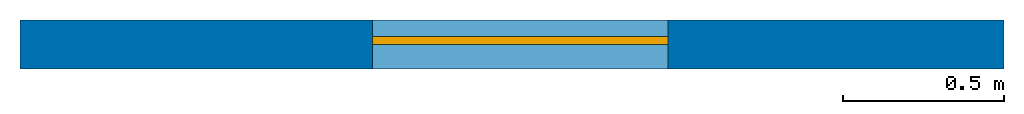
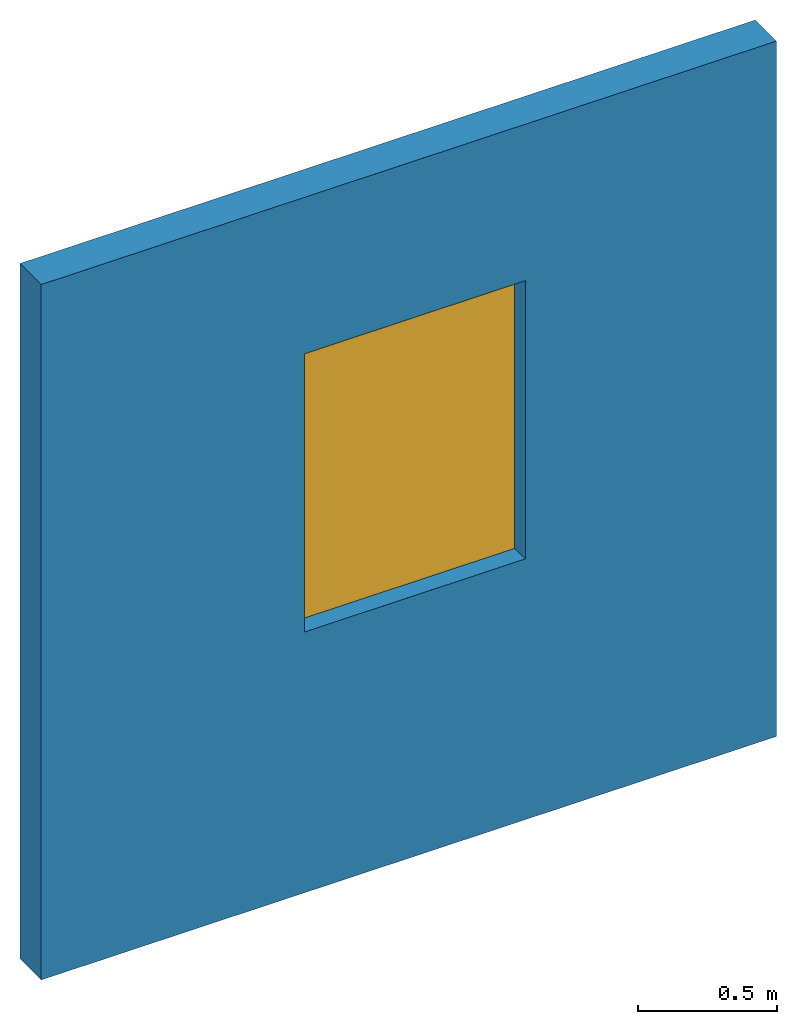
# One storey: 1 wall, 1 window, 1 opening.
"""IFC4 building model written with IfcOpenShell, lengths in feet."""

from ifc_helpers import new_model, entity, si_unit, converted_unit, derived_unit, direction, frame, frame_2d, origin, origin_2d_with_axis, place, context, subcontext, project, spatial, rectangle, extrude, source, transform, mapped, material, layer, layer_set, layer_usage, type_object, type_shapes, element, fill, save


model = new_model("IFC4")

# Units and contexts
model_context = context("Model", 3, precision=0.0001, world=origin(), true_north=direction((6.12303176911189e-17, 1.0)))
body_context = subcontext(model_context, "Body", "Model", "MODEL_VIEW")
ifc_project = project(units=[converted_unit("LENGTHUNIT", "FOOT", entity("IfcRatioMeasure", 0.3048), si_unit("LENGTHUNIT", "METRE"), dimensions=[1, 0, 0, 0, 0, 0, 0]), converted_unit("AREAUNIT", "SQUARE FOOT", entity("IfcRatioMeasure", 0.09290304), si_unit("AREAUNIT", "SQUARE_METRE"), dimensions=[2, 0, 0, 0, 0, 0, 0]), converted_unit("VOLUMEUNIT", "CUBIC FOOT", entity("IfcRatioMeasure", 0.028316846592), si_unit("VOLUMEUNIT", "CUBIC_METRE"), dimensions=[3, 0, 0, 0, 0, 0, 0]), converted_unit("PLANEANGLEUNIT", "DEGREE", entity("IfcRatioMeasure", 0.0174532925199433), si_unit("PLANEANGLEUNIT", "RADIAN"), dimensions=[0, 0, 0, 0, 0, 0, 0]), si_unit("MASSUNIT", "GRAM", prefix="KILO"), derived_unit("MASSDENSITYUNIT", [(si_unit("MASSUNIT", "GRAM", prefix="KILO"), 1), (si_unit("LENGTHUNIT", "METRE"), -3)]), derived_unit("MOMENTOFINERTIAUNIT", [(si_unit("LENGTHUNIT", "METRE"), 4)]), si_unit("TIMEUNIT", "SECOND"), si_unit("FREQUENCYUNIT", "HERTZ"), si_unit("THERMODYNAMICTEMPERATUREUNIT", "DEGREE_CELSIUS"), derived_unit("THERMALTRANSMITTANCEUNIT", [(si_unit("MASSUNIT", "GRAM", prefix="KILO"), 1), (si_unit("THERMODYNAMICTEMPERATUREUNIT", "KELVIN"), -1), (si_unit("TIMEUNIT", "SECOND"), -3)]), derived_unit("VOLUMETRICFLOWRATEUNIT", [(si_unit("LENGTHUNIT", "METRE"), 3), (si_unit("TIMEUNIT", "SECOND"), -1)]), si_unit("ELECTRICCURRENTUNIT", "AMPERE"), si_unit("ELECTRICVOLTAGEUNIT", "VOLT"), si_unit("POWERUNIT", "WATT"), si_unit("FORCEUNIT", "NEWTON"), si_unit("ILLUMINANCEUNIT", "LUX"), si_unit("LUMINOUSFLUXUNIT", "LUMEN"), si_unit("LUMINOUSINTENSITYUNIT", "CANDELA"), derived_unit("USERDEFINED", [(si_unit("MASSUNIT", "GRAM", prefix="KILO"), -1), (si_unit("LENGTHUNIT", "METRE"), -2), (si_unit("TIMEUNIT", "SECOND"), 3), (si_unit("LUMINOUSFLUXUNIT", "LUMEN"), 1)]), derived_unit("LINEARVELOCITYUNIT", [(si_unit("LENGTHUNIT", "METRE"), 1), (si_unit("TIMEUNIT", "SECOND"), -1)]), si_unit("PRESSUREUNIT", "PASCAL"), derived_unit("USERDEFINED", [(si_unit("LENGTHUNIT", "METRE"), -2), (si_unit("MASSUNIT", "GRAM", prefix="KILO"), 1), (si_unit("TIMEUNIT", "SECOND"), -2)]), derived_unit("LINEARFORCEUNIT", [(si_unit("MASSUNIT", "GRAM", prefix="KILO"), 1), (si_unit("LENGTHUNIT", "METRE"), 1), (si_unit("TIMEUNIT", "SECOND"), -2), (si_unit("LENGTHUNIT", "METRE"), -1)]), derived_unit("PLANARFORCEUNIT", [(si_unit("MASSUNIT", "GRAM", prefix="KILO"), 1), (si_unit("LENGTHUNIT", "METRE"), 1), (si_unit("TIMEUNIT", "SECOND"), -2), (si_unit("LENGTHUNIT", "METRE"), -2)])], contexts=[model_context])

# Site, building, storey
site_placement = place(None, origin())
site = spatial("IfcSite", under=ifc_project, at=site_placement, CompositionType="ELEMENT")
building_placement = place(site_placement, origin())
building = spatial("IfcBuilding", under=site, at=building_placement, CompositionType="ELEMENT")
storey_placement = place(building_placement, origin())
storey = spatial("IfcBuildingStorey", under=building, at=storey_placement, Name="Level 1", CompositionType="ELEMENT", Elevation=0.0)

# Wall, opening, window
ifc_material_1 = material(Name="MATERIAL", Category="Materials")
ifc_layer = layer(ifc_material_1, 0.5, Name="MATERIAL", Category="Materials")
ifc_layer_set = layer_set([ifc_layer], Name="Basic Wall:Wall Type")
ifc_layer_usage = layer_usage(ifc_layer_set, "AXIS2", "NEGATIVE", 0.25)
wall_type = type_object("IfcWallType", Name="Basic Wall:Wall Type", PredefinedType="STANDARD", material=ifc_layer_set)
wall_placement = place(storey_placement, frame((0.0, 0.249999999999997, 0.0)))
wall = element("IfcWall", 1, at=wall_placement, inside=storey, type_object=wall_type, material=ifc_layer_usage, Name="Basic Wall:Wall Type", ObjectType="Basic Wall:Wall Type", PredefinedType="NOTDEFINED", context=body_context, shape_type="SweptSolid", body=[
    extrude(rectangle(XDim=10.0, YDim=0.5, at=frame_2d((5.0, 0.0), x_axis=(-1.0, 0.0))), origin(), (0.0, 0.0, 1.0), 10.0),
])
opening_placement = place(wall_placement, frame((6.58333333333333, 0.249999999999979, 3.75)))
opening = element("IfcOpeningElement", 2, at=opening_placement, cuts=wall, Name="Simple_Window:Simple_Window:1", PredefinedType="OPENING", context=body_context, shape_type="SweptSolid", body=[
    extrude(rectangle(XDim=4.0, YDim=3.0, at=frame_2d((2.0, 1.5), x_axis=(-1.0, 0.0))), frame((0.0, 0.0, 0.0), z_axis=(0.0, -1.0, 0.0), x_axis=(0.0, 0.0, 1.0)), (0.0, 0.0, 1.0), 0.5),
])
ifc_material_2 = material()
window_type = type_object("IfcWindowType", Name="Simple_Window:Simple_Window", ParameterTakesPrecedence=False, PartitioningType="NOTDEFINED", PredefinedType="WINDOW", material=ifc_material_2)
shared_shape = source(origin(), body_context, "Body", "SweptSolid", [
    extrude(rectangle(XDim=0.0833333333333333, YDim=3.0, at=origin_2d_with_axis()), frame((1.5, 0.208333333333333, 0.0), z_axis=(0.0, 0.0, 1.0), x_axis=(0.0, 1.0, 0.0)), (0.0, 0.0, 1.0), 4.0),
])
type_shapes(window_type, [shared_shape])
window_placement = place(opening_placement, frame((0.0, 0.0, 0.0), z_axis=(0.0, 0.0, 1.0), x_axis=(-1.0, 0.0, 0.0)))
window = element("IfcWindow", 3, at=window_placement, inside=storey, type_object=window_type, material=ifc_material_2, Name="Simple_Window:Simple_Window", ObjectType="Simple_Window:Simple_Window", OverallHeight=4.0, OverallWidth=3.0, PartitioningType="NOTDEFINED", PredefinedType="WINDOW", context=body_context, shape_type="MappedRepresentation", body=[
    mapped(shared_shape, transform((0.0, 0.0, 0.0), scale=1.0)),
])
fill(opening, window)

save(model, "model.ifc")
